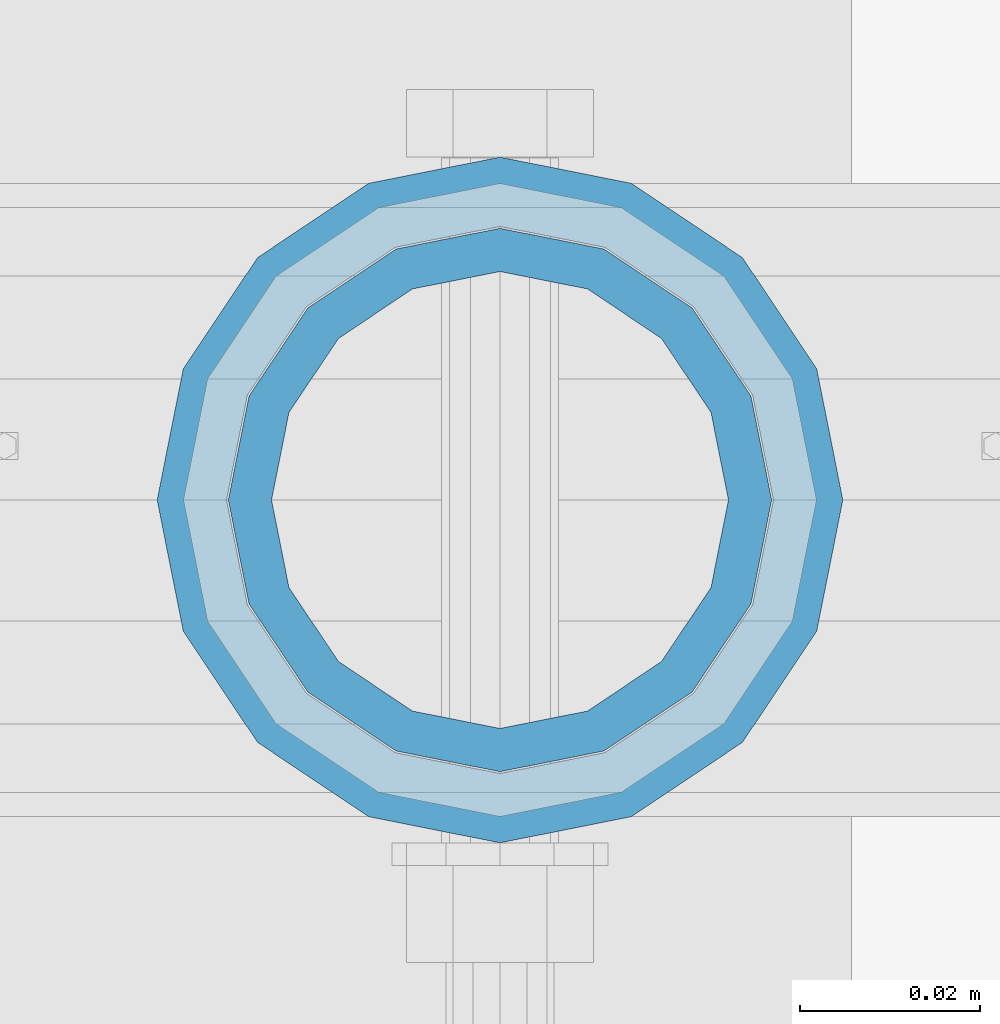
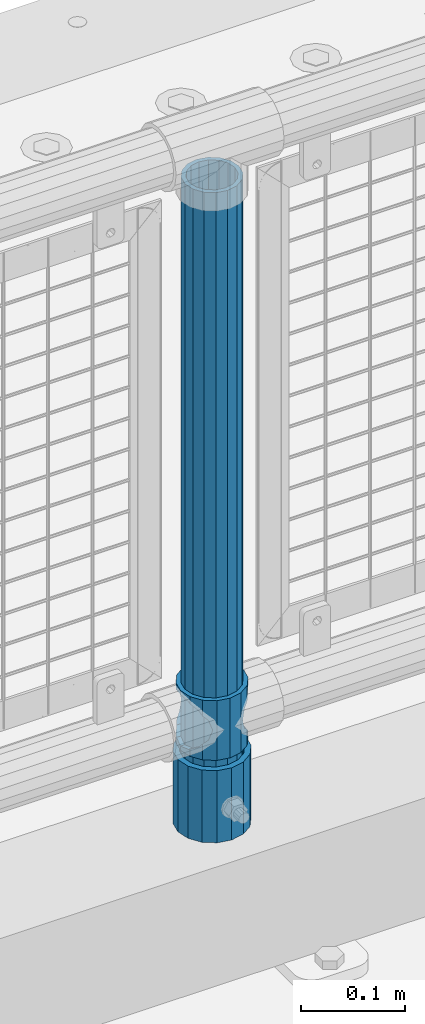
# One storey, part 89 of 247: 3 columns.
"""IFC2X3 building model written with IfcOpenShell, lengths in millimetres."""

from ifc_helpers import new_model, si_unit, frame, origin_with_axes, place, context, subcontext, project, spatial, faceted_brep, material, type_object, element, save


model = new_model("IFC2X3")

# Units and contexts
model_context = context("Model", 3, precision=1e-05, world=origin_with_axes())
body_context = subcontext(model_context, "Body", "Model", "MODEL_VIEW")
ifc_project = project(units=[si_unit("LENGTHUNIT", "METRE", prefix="MILLI"), si_unit("AREAUNIT", "SQUARE_METRE"), si_unit("VOLUMEUNIT", "CUBIC_METRE"), si_unit("MASSUNIT", "GRAM", prefix="KILO"), si_unit("TIMEUNIT", "SECOND"), si_unit("PLANEANGLEUNIT", "RADIAN"), si_unit("SOLIDANGLEUNIT", "STERADIAN"), si_unit("THERMODYNAMICTEMPERATUREUNIT", "DEGREE_CELSIUS"), si_unit("LUMINOUSINTENSITYUNIT", "LUMEN")], contexts=[model_context])

# Site, building, storey
site_placement = place(None, origin_with_axes())
site = spatial("IfcSite", under=ifc_project, at=site_placement, CompositionType="ELEMENT")
building_placement = place(site_placement, origin_with_axes())
building = spatial("IfcBuilding", under=site, at=building_placement, Name="Standard", CompositionType="ELEMENT")
storey_placement = place(building_placement, origin_with_axes())
storey = spatial("IfcBuildingStorey", under=building, at=storey_placement, Name="Undefined", CompositionType="ELEMENT", Elevation=0.0)

# Columns
ifc_material_1 = material()
column_type_1 = type_object("IfcColumnType", PredefinedType="NOTDEFINED")
column_1_placement = place(storey_placement, frame((10221.0, 7664.5, 168.02), z_axis=(0.0, 1.0, 0.0), x_axis=(0.0, 0.0, 1.0)))
element("IfcColumn", 1, at=column_1_placement, inside=storey, type_object=column_type_1, material=ifc_material_1, context=body_context, shape_type="Brep", body=[
    faceted_brep([(0.0, -31.75, 0.0), (0.0, -29.3331751572332, 12.1501989775916), (85.0, -29.3331751572332, 12.1501989775916), (85.0, -31.75, 0.0), (0.0, -22.4506403026735, 22.4506403026726), (85.0, -22.4506403026735, 22.4506403026726), (0.0, -12.1501989775916, 29.3331751572332), (85.0, -12.1501989775916, 29.3331751572332), (0.0, 0.0, 31.75), (85.0, 0.0, 31.75), (0.0, 12.1501989775916, 29.3331751572332), (85.0, 12.1501989775916, 29.3331751572332), (0.0, 22.4506403026735, 22.4506403026726), (85.0, 22.4506403026735, 22.4506403026726), (0.0, 29.3331751572332, 12.1501989775916), (85.0, 29.3331751572332, 12.1501989775916), (0.0, 31.75, 0.0), (85.0, 31.75, 0.0), (0.0, 29.3331751572332, -12.1501989775916), (85.0, 29.3331751572332, -12.1501989775916), (0.0, 22.4506403026735, -22.4506403026726), (85.0, 22.4506403026735, -22.4506403026726), (0.0, 12.1501989775916, -29.3331751572332), (85.0, 12.1501989775916, -29.3331751572332), (0.0, 0.0, -31.75), (85.0, 0.0, -31.75), (0.0, -12.1501989775916, -29.3331751572332), (85.0, -12.1501989775916, -29.3331751572332), (0.0, -22.4506403026735, -22.4506403026726), (85.0, -22.4506403026735, -22.4506403026726), (0.0, -29.3331751572332, -12.1501989775916), (85.0, -29.3331751572332, -12.1501989775916), (0.0, -38.0499999999993, 0.0), (0.0, -35.1536162120537, -14.5611046014919), (85.0, -35.1536162120537, -14.5611046014919), (85.0, -38.0499999999993, 0.0), (0.0, -26.9054130241475, -26.9054130241484), (85.0, -26.9054130241475, -26.9054130241484), (0.0, -14.561104601491, -35.1536162120547), (85.0, -14.561104601491, -35.1536162120547), (0.0, 0.0, -38.0500000000002), (85.0, 0.0, -38.0500000000002), (0.0, 14.561104601491, -35.1536162120547), (85.0, 14.561104601491, -35.1536162120547), (0.0, 26.9054130241475, -26.9054130241484), (85.0, 26.9054130241475, -26.9054130241484), (0.0, 35.1536162120537, -14.5611046014919), (85.0, 35.1536162120537, -14.5611046014919), (0.0, 38.0499999999993, 0.0), (85.0, 38.0499999999993, 0.0), (0.0, 35.1536162120537, 14.5611046014919), (85.0, 35.1536162120537, 14.5611046014919), (0.0, 26.9054130241475, 26.9054130241484), (85.0, 26.9054130241475, 26.9054130241484), (0.0, 14.561104601491, 35.1536162120547), (85.0, 14.561104601491, 35.1536162120547), (0.0, 0.0, 38.0500000000002), (85.0, 0.0, 38.0500000000002), (0.0, -14.561104601491, 35.1536162120547), (85.0, -14.561104601491, 35.1536162120547), (0.0, -26.9054130241475, 26.9054130241484), (85.0, -26.9054130241475, 26.9054130241484), (0.0, -35.1536162120537, 14.5611046014919), (85.0, -35.1536162120537, 14.5611046014919)], [[[0, 1, 2, 3]], [[1, 4, 5, 2]], [[4, 6, 7, 5]], [[6, 8, 9, 7]], [[8, 10, 11, 9]], [[10, 12, 13, 11]], [[12, 14, 15, 13]], [[14, 16, 17, 15]], [[16, 18, 19, 17]], [[18, 20, 21, 19]], [[20, 22, 23, 21]], [[22, 24, 25, 23]], [[24, 26, 27, 25]], [[26, 28, 29, 27]], [[28, 30, 31, 29]], [[30, 0, 3, 31]], [[32, 33, 34, 35]], [[33, 36, 37, 34]], [[36, 38, 39, 37]], [[38, 40, 41, 39]], [[40, 42, 43, 41]], [[42, 44, 45, 43]], [[44, 46, 47, 45]], [[46, 48, 49, 47]], [[48, 50, 51, 49]], [[50, 52, 53, 51]], [[52, 54, 55, 53]], [[54, 56, 57, 55]], [[56, 58, 59, 57]], [[58, 60, 61, 59]], [[60, 62, 63, 61]], [[62, 32, 35, 63]], [[37, 39, 41, 43, 45, 47, 49, 51, 53, 55, 57, 59, 61, 63, 35, 34], [5, 7, 9, 11, 13, 15, 17, 19, 21, 23, 25, 27, 29, 31, 3, 2]], [[62, 60, 58, 56, 54, 52, 50, 48, 46, 44, 42, 40, 38, 36, 33, 32], [30, 28, 26, 24, 22, 20, 18, 16, 14, 12, 10, 8, 6, 4, 1, 0]]]),
])
ifc_material_2 = material(Name="Misc_Undefined")
column_type_2 = type_object("IfcColumnType", PredefinedType="NOTDEFINED")
column_2_placement = place(storey_placement, frame((10221.0, 7664.5, 263.02), z_axis=(-1.0, 0.0, 0.0), x_axis=(0.0, 0.0, 1.0)))
element("IfcColumn", 2, at=column_2_placement, inside=storey, type_object=column_type_2, material=ifc_material_2, context=body_context, shape_type="Brep", body=[
    faceted_brep([(56.6106908090114, 21.4606908090118, -21.4606908090118), (56.6106908090114, 21.4606908090118, -27.1226768591096), (61.9623795176755, 13.4513226476329, -32.4743655677721), (63.1897438117172, 11.6144421722802, -32.839743811719), (63.1897438117172, 11.6144421722802, -28.0397438117179), (46.7644421722801, 28.0397438117179, -11.6144421722802), (46.7644421722801, 28.0397438117179, -20.088203122983), (51.5310424080055, 24.8548033587067, -24.8548033587067), (35.1499999999996, 30.35, 0.0), (35.1499999999996, 30.3500000000004, -16.6306603983649), (23.5355578277192, 28.0397438117179, -11.6144421722802), (23.5355578277192, 28.0397438117179, -20.088203122983), (13.6893091909879, 21.4606908090118, -21.4606908090118), (13.6893091909879, 21.4606908090118, -27.1226768591096), (18.768957591997, 24.8548033587067, -24.8548033587067), (7.11025618828211, 11.6144421722802, -28.0397438117179), (7.11025618828211, 11.6144421722802, -32.839743811719), (8.33762048232387, 13.4513226476329, -32.4743655677721), (4.79999999999961, 0.0, -30.3500000000004), (4.79999999999961, 0.0, -35.1499999999996), (7.11025618828211, -11.6144421722802, -28.0397438117179), (7.11025618828211, -11.6144421722802, -32.839743811719), (13.6893091909879, -21.4606908090118, -21.4606908090118), (13.6893091909879, -21.4606908090118, -27.1226768591077), (8.33762048232325, -13.4513226476329, -32.4743655677721), (23.5355578277191, -28.0397438117179, -11.6144421722802), (23.5355578277191, -28.0397438117179, -20.0882031229885), (18.768957591997, -24.8548033587067, -24.8548033587067), (35.1499999999996, -30.35, 0.0), (35.1499999999996, -30.3500000000004, -16.6306603983739), (46.7644421722801, -28.0397438117179, -11.6144421722802), (46.7644421722801, -28.0397438117179, -20.0882031229885), (56.6106908090114, -21.4606908090118, -21.4606908090118), (56.6106908090114, -21.4606908090118, -27.1226768591077), (51.5310424080038, -24.8548033587067, -24.8548033587067), (63.1897438117172, -11.6144421722802, -28.0397438117179), (63.1897438117172, -11.6144421722802, -32.839743811719), (61.9623795176754, -13.4513226476329, -32.4743655677721), (65.4999999999997, 0.0, -30.3500000000004), (65.4999999999997, 0.0, -35.1499999999996), (0.0, -28.0397438117179, -11.6144421722802), (0.0, -30.3500000000004, 0.0), (0.0, -21.4606908090118, -21.4606908090118), (0.0, -11.6144421722802, -28.0397438117179), (0.0, 0.0, -30.3500000000004), (0.0, 11.6144421722802, -28.0397438117179), (0.0, 21.4606908090118, -21.4606908090118), (0.0, 28.0397438117179, -11.6144421722802), (0.0, 30.3500000000004, 0.0), (0.0, 28.0397438117179, 11.6144421722802), (23.5355578277192, 28.0397438117179, 11.6144421722806), (0.0, 21.4606908090118, 21.4606908090118), (13.6893091909879, 21.4606908090118, 21.4606908090118), (0.0, 11.6144421722802, 28.0397438117179), (7.11025618828211, 11.6144421722802, 28.0397438117175), (0.0, 0.0, 30.3500000000004), (4.79999999999961, 0.0, 30.3499999999999), (0.0, -11.6144421722802, 28.0397438117179), (7.11025618828205, -11.6144421722802, 28.0397438117175), (0.0, -21.4606908090118, 21.4606908090118), (13.6893091909879, -21.4606908090118, 21.4606908090118), (0.0, -28.0397438117179, 11.6144421722802), (23.5355578277191, -28.0397438117179, 11.6144421722806), (0.0, -32.4743655677721, 13.4513226476338), (0.0, -35.1499999999996, 0.0), (70.2999999999993, -35.1499999999996, 0.0), (70.2999999999993, -32.4743655677721, 13.4513226476338), (0.0, 13.4513226476329, -32.4743655677721), (0.0, 24.8548033587067, -24.8548033587067), (0.0, 0.0, -35.1499999999996), (0.0, -13.4513226476329, -32.4743655677721), (0.0, -24.8548033587067, -24.8548033587067), (0.0, -24.8548033587067, 24.8548033587067), (0.0, -13.4513226476329, 32.4743655677721), (0.0, 0.0, 35.1499999999996), (0.0, 13.4513226476329, 32.4743655677721), (0.0, 24.8548033587067, 24.8548033587067), (0.0, 32.4743655677721, 13.4513226476338), (0.0, 35.1499999999996, 0.0), (0.0, 32.4743655677721, -13.4513226476338), (0.0, -32.4743655677721, -13.4513226476338), (70.2999999999993, 32.4743655677721, 13.4513226476338), (70.2999999999993, 35.1499999999996, 0.0), (70.2999999999993, 32.4743655677721, -13.4513226476338), (70.2999999999993, 24.8548033587067, -24.8548033587067), (70.2999999999993, 13.4513226476329, -32.4743655677721), (70.2999999999993, 0.0, -35.1499999999996), (70.2999999999993, -13.4513226476329, -32.4743655677721), (70.2999999999993, -24.8548033587067, -24.8548033587067), (70.2999999999993, -32.4743655677721, -13.4513226476338), (70.2999999999993, 28.0397438117179, 11.6144421722802), (70.2999999999993, 21.4606908090118, 21.4606908090118), (56.6106908090114, 21.4606908090118, 21.4606908090118), (46.7644421722801, 28.0397438117179, 11.6144421722806), (70.2999999999993, 11.6144421722802, 28.0397438117179), (63.1897438117172, 11.6144421722802, 28.0397438117175), (70.2999999999993, 0.0, 30.3500000000004), (65.4999999999997, 0.0, 30.3499999999999), (70.2999999999993, -11.6144421722802, 28.0397438117179), (63.1897438117172, -11.6144421722802, 28.0397438117175), (70.2999999999993, -21.4606908090118, 21.4606908090118), (56.6106908090114, -21.4606908090118, 21.4606908090118), (70.2999999999993, -28.0397438117179, 11.6144421722802), (46.7644421722801, -28.0397438117179, 11.6144421722806), (70.2999999999993, -11.6144421722802, -28.0397438117179), (70.2999999999993, 0.0, -30.3500000000004), (70.2999999999993, -21.4606908090118, -21.4606908090118), (70.2999999999993, -28.0397438117179, -11.6144421722802), (70.2999999999993, -30.3500000000004, 0.0), (70.2999999999993, 24.8548033587067, 24.8548033587067), (70.2999999999993, 13.4513226476329, 32.4743655677721), (70.2999999999993, 0.0, 35.1499999999996), (70.2999999999993, -13.4513226476329, 32.4743655677721), (70.2999999999993, -24.8548033587067, 24.8548033587067), (70.2999999999993, 30.3500000000004, 0.0), (70.2999999999993, 28.0397438117179, -11.6144421722802), (70.2999999999993, 21.4606908090118, -21.4606908090118), (70.2999999999993, 11.6144421722802, -28.0397438117179), (61.9623795176755, 13.4513226476329, 32.4743655677717), (51.5310424080043, 24.8548033587067, 24.8548033587072), (56.6106908090114, 21.4606908090118, 27.1226768591082), (65.4999999999997, 0.0, 35.1500000000001), (63.1897438117172, 11.6144421722802, 32.8397438117177), (63.1897438117172, -11.6144421722802, 32.8397438117177), (61.962379517675, -13.4513226476329, 32.4743655677717), (56.6106908090114, -21.4606908090118, 27.1226768591068), (51.5310424080026, -24.8548033587067, 24.8548033587072), (18.7689575919956, -24.8548033587067, 24.8548033587072), (46.7644421722801, -28.0397438117179, 20.088203122983), (35.1499999999996, -30.3500000000004, 16.6306603983649), (23.5355578277191, -28.0397438117179, 20.088203122983), (8.33762048232268, -13.4513226476329, 32.4743655677717), (13.6893091909879, -21.4606908090118, 27.1226768591068), (4.79999999999961, 0.0, 35.1500000000001), (7.11025618828205, -11.6144421722802, 32.8397438117177), (7.11025618828211, 11.6144421722802, 32.8397438117177), (8.33762048232427, 13.4513226476329, 32.4743655677717), (13.6893091909879, 21.4606908090118, 27.1226768591082), (18.7689575919966, 24.8548033587067, 24.8548033587072), (23.5355578277192, 28.0397438117179, 20.0882031229844), (35.1499999999996, 30.3500000000004, 16.6306603983667), (46.7644421722801, 28.0397438117179, 20.0882031229844)], [[[0, 1, 2, 3, 4]], [[5, 6, 7, 1, 0]], [[8, 9, 6, 5]], [[10, 11, 9, 8]], [[12, 13, 14, 11, 10]], [[15, 16, 17, 13, 12]], [[18, 19, 16, 15]], [[20, 21, 19, 18]], [[22, 23, 24, 21, 20]], [[25, 26, 27, 23, 22]], [[28, 29, 26, 25]], [[30, 31, 29, 28]], [[32, 33, 34, 31, 30]], [[35, 36, 37, 33, 32]], [[38, 39, 36, 35]], [[4, 3, 39, 38]], [[40, 41, 28, 25]], [[42, 40, 25, 22]], [[43, 42, 22, 20]], [[44, 43, 20, 18]], [[45, 44, 18, 15]], [[46, 45, 15, 12]], [[47, 46, 12, 10]], [[48, 47, 10, 8]], [[49, 48, 8, 50]], [[51, 49, 50, 52]], [[53, 51, 52, 54]], [[55, 53, 54, 56]], [[57, 55, 56, 58]], [[59, 57, 58, 60]], [[61, 59, 60, 62]], [[41, 61, 62, 28]], [[63, 64, 65, 66]], [[17, 67, 68, 14, 13]], [[19, 69, 67, 17, 16]], [[70, 69, 19, 21, 24]], [[71, 70, 24, 23, 27]], [[63, 72, 73, 74, 75, 76, 77, 78, 79, 68, 67, 69, 70, 71, 80, 64], [40, 42, 43, 44, 45, 46, 47, 48, 49, 51, 53, 55, 57, 59, 61, 41]], [[78, 77, 81, 82]], [[79, 78, 82, 83]], [[14, 68, 79, 83, 84, 7, 6, 9, 11]], [[84, 85, 2, 1, 7]], [[85, 86, 39, 3, 2]], [[37, 87, 88, 34, 33]], [[39, 86, 87, 37, 36]], [[34, 88, 89, 80, 71, 27, 26, 29, 31]], [[64, 80, 89, 65]], [[90, 91, 92, 93]], [[91, 94, 95, 92]], [[94, 96, 97, 95]], [[96, 98, 99, 97]], [[98, 100, 101, 99]], [[100, 102, 103, 101]], [[104, 105, 38, 35]], [[106, 104, 35, 32]], [[107, 106, 32, 30]], [[108, 107, 30, 28]], [[102, 108, 28, 103]], [[88, 87, 86, 85, 84, 83, 82, 81, 109, 110, 111, 112, 113, 66, 65, 89], [100, 98, 96, 94, 91, 90, 114, 115, 116, 117, 105, 104, 106, 107, 108, 102]], [[118, 110, 109, 119, 120]], [[121, 111, 110, 118, 122]], [[112, 111, 121, 123, 124]], [[113, 112, 124, 125, 126]], [[127, 72, 63, 66, 113, 126, 128, 129, 130]], [[131, 73, 72, 127, 132]], [[133, 74, 73, 131, 134]], [[75, 74, 133, 135, 136]], [[76, 75, 136, 137, 138]], [[119, 109, 81, 77, 76, 138, 139, 140, 141]], [[92, 120, 119, 141, 93]], [[95, 122, 118, 120, 92]], [[97, 121, 122, 95]], [[99, 123, 121, 97]], [[101, 125, 124, 123, 99]], [[103, 128, 126, 125, 101]], [[28, 129, 128, 103]], [[62, 130, 129, 28]], [[60, 132, 127, 130, 62]], [[58, 134, 131, 132, 60]], [[56, 133, 134, 58]], [[54, 135, 133, 56]], [[52, 137, 136, 135, 54]], [[50, 139, 138, 137, 52]], [[8, 140, 139, 50]], [[93, 141, 140, 8]], [[114, 90, 93, 8]], [[115, 114, 8, 5]], [[116, 115, 5, 0]], [[117, 116, 0, 4]], [[105, 117, 4, 38]]]),
])
column_type_3 = type_object("IfcColumnType", PredefinedType="NOTDEFINED")
column_3_placement = place(storey_placement, frame((10221.0, 7664.5, 168.02), z_axis=(-1.0, 0.0, 0.0), x_axis=(0.0, 0.0, 1.0)))
element("IfcColumn", 3, at=column_3_placement, inside=storey, type_object=column_type_3, material=ifc_material_1, context=body_context, shape_type="Brep", body=[
    faceted_brep([(0.0, -25.3500000000004, 0.0), (0.0, -23.4203461491616, 9.70102501045585), (760.0, -23.4203461491616, 9.70102501045585), (760.0, -25.3500000000004, 0.0), (0.0, -17.9251569030794, 17.9251569030785), (760.0, -17.9251569030794, 17.9251569030785), (0.0, -9.70102501045494, 23.4203461491616), (760.0, -9.70102501045494, 23.4203461491616), (0.0, 0.0, 25.3500000000004), (760.0, 0.0, 25.3500000000004), (0.0, 9.70102501045494, 23.4203461491616), (760.0, 9.70102501045494, 23.4203461491616), (0.0, 17.9251569030794, 17.9251569030785), (760.0, 17.9251569030794, 17.9251569030785), (0.0, 23.4203461491616, 9.70102501045585), (760.0, 23.4203461491616, 9.70102501045585), (0.0, 25.3500000000004, 0.0), (760.0, 25.3500000000004, 0.0), (0.0, 23.4203461491616, -9.70102501045585), (760.0, 23.4203461491616, -9.70102501045585), (0.0, 17.9251569030794, -17.9251569030785), (760.0, 17.9251569030794, -17.9251569030785), (0.0, 9.70102501045494, -23.4203461491616), (760.0, 9.70102501045494, -23.4203461491616), (0.0, 0.0, -25.3500000000004), (760.0, 0.0, -25.3500000000004), (0.0, -9.70102501045494, -23.4203461491616), (760.0, -9.70102501045494, -23.4203461491616), (0.0, -17.9251569030794, -17.9251569030785), (760.0, -17.9251569030794, -17.9251569030785), (0.0, -23.4203461491616, -9.70102501045585), (760.0, -23.4203461491616, -9.70102501045585), (0.0, -30.1499999999996, 0.0), (0.0, -27.8549679052148, -11.5379054858076), (760.0, -27.8549679052148, -11.5379054858076), (760.0, -30.1499999999996, 0.0), (0.0, -21.3192694527743, -21.3192694527752), (760.0, -21.3192694527743, -21.3192694527752), (0.0, -11.5379054858076, -27.8549679052157), (760.0, -11.5379054858076, -27.8549679052157), (0.0, 0.0, -30.1499999999996), (760.0, 0.0, -30.1499999999996), (0.0, 11.5379054858076, -27.8549679052157), (760.0, 11.5379054858076, -27.8549679052157), (0.0, 21.3192694527743, -21.3192694527752), (760.0, 21.3192694527743, -21.3192694527752), (0.0, 27.8549679052157, -11.5379054858076), (760.0, 27.8549679052157, -11.5379054858076), (0.0, 30.1499999999996, 0.0), (760.0, 30.1499999999996, 0.0), (0.0, 27.8549679052157, 11.5379054858076), (760.0, 27.8549679052157, 11.5379054858076), (0.0, 21.3192694527743, 21.3192694527752), (760.0, 21.3192694527743, 21.3192694527752), (0.0, 11.5379054858076, 27.8549679052157), (760.0, 11.5379054858076, 27.8549679052157), (0.0, 0.0, 30.1499999999996), (760.0, 0.0, 30.1499999999996), (0.0, -11.5379054858076, 27.8549679052157), (760.0, -11.5379054858076, 27.8549679052157), (0.0, -21.3192694527743, 21.3192694527752), (760.0, -21.3192694527743, 21.3192694527752), (0.0, -27.8549679052157, 11.5379054858076), (760.0, -27.8549679052157, 11.5379054858076)], [[[0, 1, 2, 3]], [[1, 4, 5, 2]], [[4, 6, 7, 5]], [[6, 8, 9, 7]], [[8, 10, 11, 9]], [[10, 12, 13, 11]], [[12, 14, 15, 13]], [[14, 16, 17, 15]], [[16, 18, 19, 17]], [[18, 20, 21, 19]], [[20, 22, 23, 21]], [[22, 24, 25, 23]], [[24, 26, 27, 25]], [[26, 28, 29, 27]], [[28, 30, 31, 29]], [[30, 0, 3, 31]], [[32, 33, 34, 35]], [[33, 36, 37, 34]], [[36, 38, 39, 37]], [[38, 40, 41, 39]], [[40, 42, 43, 41]], [[42, 44, 45, 43]], [[44, 46, 47, 45]], [[46, 48, 49, 47]], [[48, 50, 51, 49]], [[50, 52, 53, 51]], [[52, 54, 55, 53]], [[54, 56, 57, 55]], [[56, 58, 59, 57]], [[58, 60, 61, 59]], [[60, 62, 63, 61]], [[62, 32, 35, 63]], [[37, 39, 41, 43, 45, 47, 49, 51, 53, 55, 57, 59, 61, 63, 35, 34], [5, 7, 9, 11, 13, 15, 17, 19, 21, 23, 25, 27, 29, 31, 3, 2]], [[62, 60, 58, 56, 54, 52, 50, 48, 46, 44, 42, 40, 38, 36, 33, 32], [30, 28, 26, 24, 22, 20, 18, 16, 14, 12, 10, 8, 6, 4, 1, 0]]]),
])

save(model, "model.ifc")
